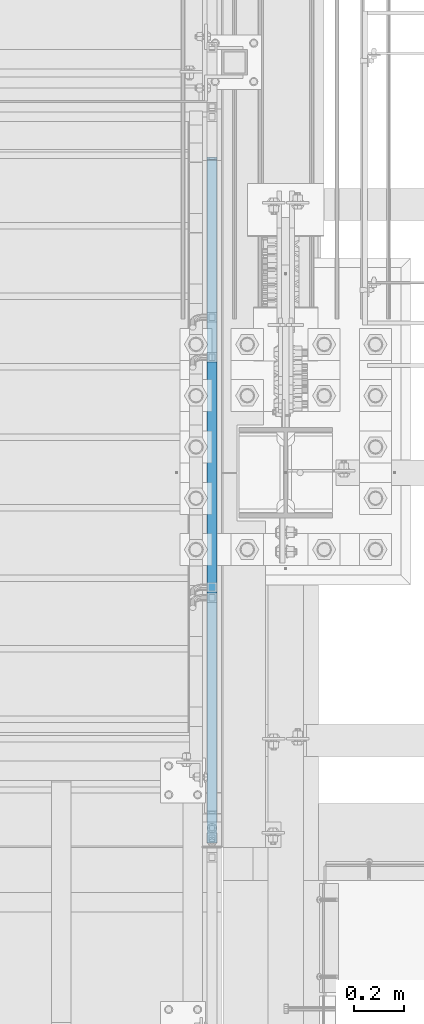
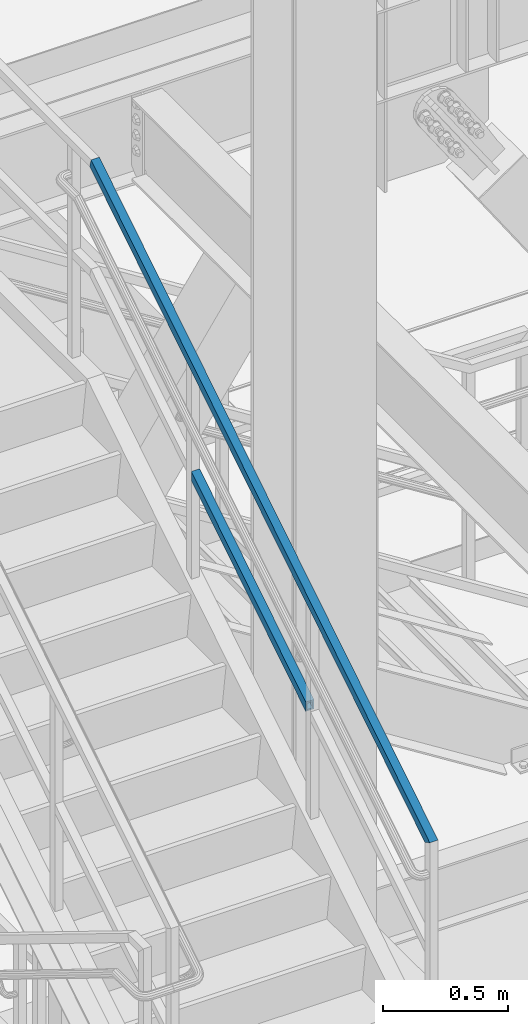
# One storey, part 1771 of 3843: 2 members, 1 element without a shape of its own.
"""IFC2X3 building model written with IfcOpenShell, lengths in millimetres."""

from ifc_helpers import new_model, si_unit, frame, origin_with_axes, place, context, subcontext, project, spatial, faceted_brep, material, type_object, element, aggregate, save


model = new_model("IFC2X3")

# Units and contexts
model_context = context("Model", 3, precision=1e-05, world=origin_with_axes())
body_context = subcontext(model_context, "Body", "Model", "MODEL_VIEW")
ifc_project = project(units=[si_unit("LENGTHUNIT", "METRE", prefix="MILLI"), si_unit("AREAUNIT", "SQUARE_METRE"), si_unit("VOLUMEUNIT", "CUBIC_METRE"), si_unit("MASSUNIT", "GRAM", prefix="KILO"), si_unit("TIMEUNIT", "SECOND"), si_unit("PLANEANGLEUNIT", "RADIAN"), si_unit("SOLIDANGLEUNIT", "STERADIAN"), si_unit("THERMODYNAMICTEMPERATUREUNIT", "DEGREE_CELSIUS"), si_unit("LUMINOUSINTENSITYUNIT", "LUMEN")], contexts=[model_context])

# Site, building, storey
site_placement = place(None, origin_with_axes())
site = spatial("IfcSite", under=ifc_project, at=site_placement, CompositionType="ELEMENT")
building_placement = place(site_placement, origin_with_axes())
building = spatial("IfcBuilding", under=site, at=building_placement, Name="Undefined", CompositionType="ELEMENT")
storey_placement = place(building_placement, origin_with_axes())
storey = spatial("IfcBuildingStorey", under=building, at=storey_placement, Name="Undefined", CompositionType="ELEMENT", Elevation=0.0)

# Assembly, members
assembly_placement = place(storey_placement, origin_with_axes())
assembly = element("IfcElementAssembly", 1, at=assembly_placement, inside=storey, Name="RAIL", AssemblyPlace="NOTDEFINED", PredefinedType="RIGID_FRAME")
ifc_material = material()
member_type = type_object("IfcMemberType", Name="HSS1-1/2X1-1/2X1/4", PredefinedType="NOTDEFINED")
member_1_placement = place(assembly_placement, frame((55638.7000000038, 19812.0000000041, 36141.8139374921), z_axis=(0.0, -0.529536736899111, 0.848287005838379), x_axis=(0.0, 0.848287005838377, 0.529536736899114)))
member_1 = element("IfcMember", 2, at=member_1_placement, type_object=member_type, material=ifc_material, Name="RAIL", ObjectType="HSS1-1/2X1-1/2X1/4", context=body_context, shape_type="Brep", body=[
    faceted_brep([(34.3488397583606, -19.0499999999956, 19.0499992348923), (34.3488397583606, 19.0499992350015, 19.0499992348923), (10.5652043534537, 19.0499992350015, -19.0499992349432), (10.5652043534537, -19.0499992350015, -19.0499992349432), (30.3849004243275, -12.6999993300014, 12.6999993299178), (14.5291436874832, -12.6999993300014, -12.6999993299687), (14.5291436874832, 12.6999993300014, -12.6999993299687), (30.3849004243275, 12.6999993300014, 12.6999993299178), (1088.50226304266, 19.0499992350015, -19.0499992383411), (1088.50226304266, -19.0499992350015, -19.0499992383411), (1112.28589844752, -19.0499992350015, 19.0499992315272), (1112.28589844752, 19.0499992350015, 19.0499992315272), (1108.32195911351, -12.6999993299978, 12.699999326549), (1108.32195911351, 12.6999993299978, 12.699999326549), (1092.46620237669, 12.6999993299978, -12.6999993333629), (1092.46620237669, -12.6999993299978, -12.6999993333629)], [[[0, 1, 2, 3], [4, 5, 6, 7]], [[8, 9, 3, 2]], [[9, 10, 0, 3]], [[10, 11, 1, 0]], [[11, 8, 2, 1]], [[10, 9, 8, 11], [12, 13, 14, 15]], [[13, 12, 4, 7]], [[14, 13, 7, 6]], [[15, 14, 6, 5]], [[12, 15, 5, 4]]]),
])
member_2_placement = place(assembly_placement, frame((55638.6999999932, 21551.9000000515, 37761.3333313075), z_axis=(0.0, 0.529536736899111, -0.848287005838379), x_axis=(0.0, -0.848287005838377, -0.529536736899114)))
member_2 = element("IfcMember", 3, at=member_2_placement, type_object=member_type, material=ifc_material, Name="RAIL", ObjectType="HSS1-1/2X1-1/2X1/4", context=body_context, shape_type="Brep", body=[
    faceted_brep([(-3.63856705526268, 12.6999993300014, -12.6999993299469), (-3.63856705526268, -12.6999993300014, -12.6999993299469), (3180.96925284948, -12.6999993299978, -12.6999993398349), (3180.96925284948, 12.6999993299978, -12.6999993398349), (3.63856705247599, -12.6999993300014, 12.6999993299542), (3166.88231510687, -12.6999993299978, 12.6999993201716), (3.63856705247599, 12.6999993300014, 12.6999993299542), (3166.88231510687, 12.6999993299978, 12.6999993201716), (-5.45785065095697, 19.0499992350015, -19.0499992349214), (5.45785064817028, 19.0499992350015, 19.0499992349287), (3163.36058053812, 19.0499992350015, 19.0499992251644), (3184.49098741823, 19.0499992350015, -19.0499992448349), (5.45785064817028, -19.0499992350015, 19.0499992349287), (3163.36058053812, -19.0499992350015, 19.0499992251644), (-5.45785065095697, -19.0499992350015, -19.0499992349214), (3184.49098741823, -19.0499992350015, -19.0499992448349)], [[[0, 1, 2, 3]], [[1, 4, 5, 2]], [[4, 6, 7, 5]], [[6, 0, 3, 7]], [[8, 9, 10, 11]], [[9, 12, 13, 10]], [[12, 14, 15, 13]], [[14, 8, 11, 15]], [[13, 15, 11, 10], [5, 7, 3, 2]], [[14, 12, 9, 8], [6, 4, 1, 0]]]),
])
aggregate(assembly, [member_1, member_2])

save(model, "model.ifc")
